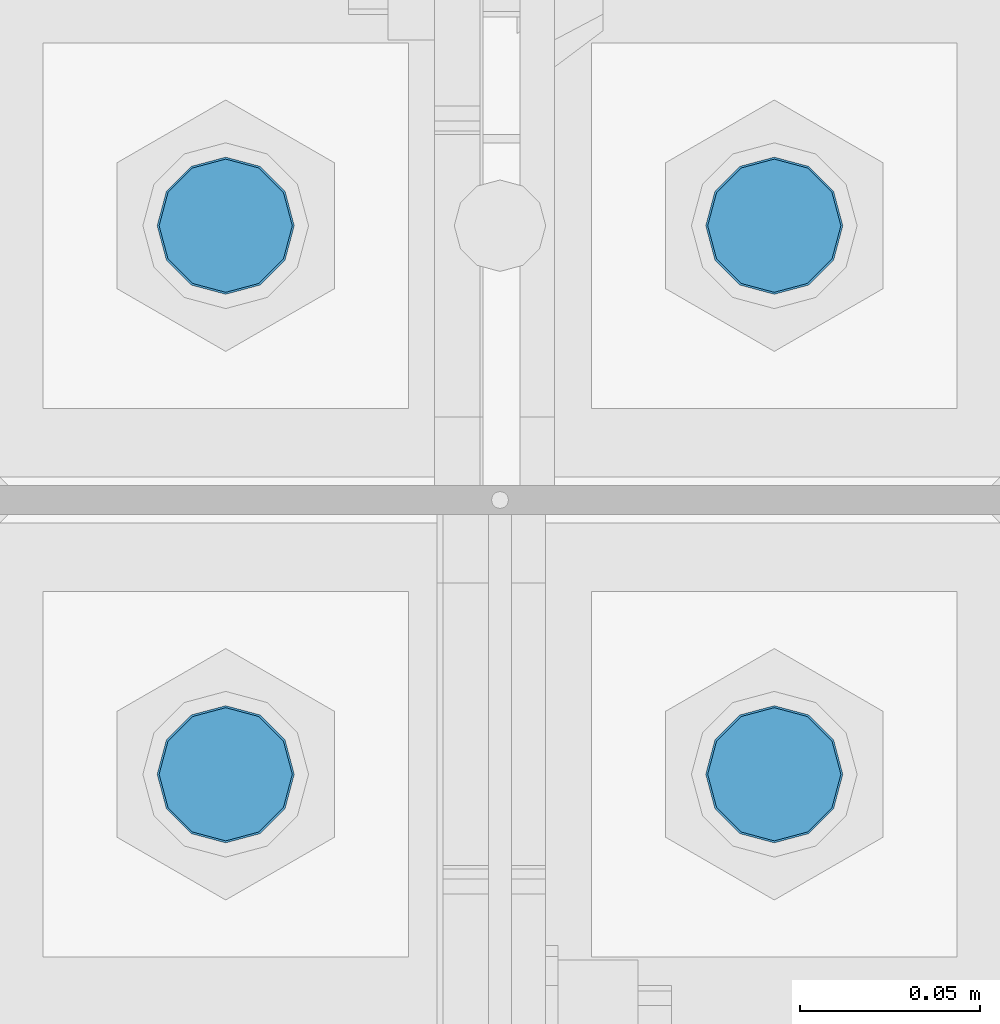
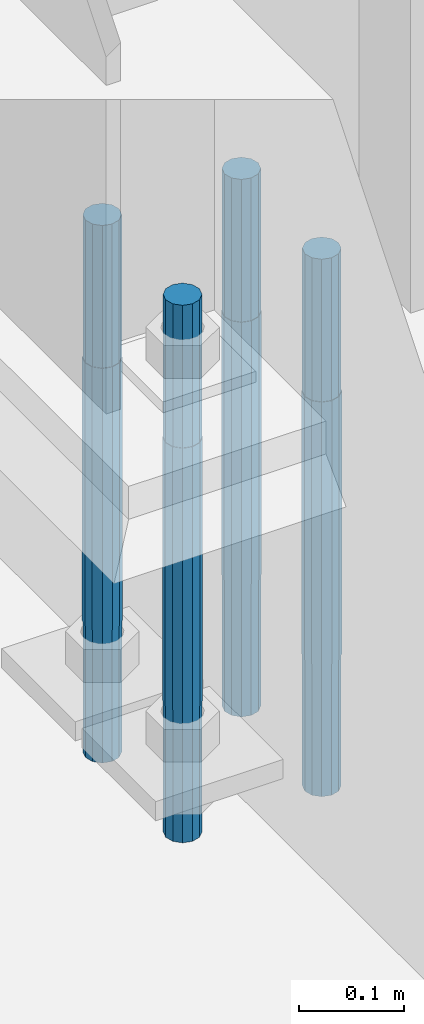
# One storey, part 1503 of 3843: 4 columns, 1 element without a shape of its own.
"""IFC2X3 building model written with IfcOpenShell, lengths in millimetres."""

from ifc_helpers import new_model, si_unit, frame, origin_with_axes, place, context, subcontext, project, spatial, faceted_brep, material, type_object, element, aggregate, save


model = new_model("IFC2X3")

# Units and contexts
model_context = context("Model", 3, precision=1e-05, world=origin_with_axes())
body_context = subcontext(model_context, "Body", "Model", "MODEL_VIEW")
ifc_project = project(units=[si_unit("LENGTHUNIT", "METRE", prefix="MILLI"), si_unit("AREAUNIT", "SQUARE_METRE"), si_unit("VOLUMEUNIT", "CUBIC_METRE"), si_unit("MASSUNIT", "GRAM", prefix="KILO"), si_unit("TIMEUNIT", "SECOND"), si_unit("PLANEANGLEUNIT", "RADIAN"), si_unit("SOLIDANGLEUNIT", "STERADIAN"), si_unit("THERMODYNAMICTEMPERATUREUNIT", "DEGREE_CELSIUS"), si_unit("LUMINOUSINTENSITYUNIT", "LUMEN")], contexts=[model_context])

# Site, building, storey
site_placement = place(None, origin_with_axes())
site = spatial("IfcSite", under=ifc_project, at=site_placement, CompositionType="ELEMENT")
building_placement = place(site_placement, origin_with_axes())
building = spatial("IfcBuilding", under=site, at=building_placement, Name="Undefined", CompositionType="ELEMENT")
storey_placement = place(building_placement, origin_with_axes())
storey = spatial("IfcBuildingStorey", under=building, at=storey_placement, Name="Undefined", CompositionType="ELEMENT", Elevation=0.0)

# Assembly, columns
assembly_placement = place(storey_placement, origin_with_axes())
assembly = element("IfcElementAssembly", 1, at=assembly_placement, inside=storey, Name="TEMPLATE", AssemblyPlace="NOTDEFINED", PredefinedType="RIGID_FRAME")
ifc_material = material(Name="Undefined/F1554-GR.55")
column_type = type_object("IfcColumnType", PredefinedType="NOTDEFINED")
column_1_placement = place(assembly_placement, frame((77089.0, 28638.5, 30022.8), z_axis=(1.0, 0.0, 0.0), x_axis=(0.0, 0.0, -1.0)))
column_1 = element("IfcColumn", 2, at=column_1_placement, type_object=column_type, material=ifc_material, Name="ANCHOR_ROD", context=body_context, shape_type="Brep", body=[
    faceted_brep([(-165.100000000002, -16.0214699700118, 9.25), (-165.100000000002, -9.25, 16.0214699700155), (-165.100000000002, 0.0, 18.5), (-165.100000000002, 9.25, 16.0214699700155), (-165.100000000002, 16.0214699700118, 9.25), (-165.100000000002, 18.5, 0.0), (-165.100000000002, 16.0214699700118, -9.25), (-165.100000000002, 9.25, -16.0214699700155), (-165.100000000002, 0.0, -18.5), (-165.100000000002, -9.25, -16.0214699700155), (-165.100000000002, -16.0214699700118, -9.25), (-165.100000000002, -18.5, 0.0), (0.0, 18.5, 0.0), (0.0, 16.0214699700118, -9.25), (0.0, 9.25, -16.0214699700155), (0.0, 0.0, -18.5), (0.0, -9.25, -16.0214699700155), (0.0, -16.0214699700118, -9.25), (0.0, -18.5, 0.0), (0.0, -16.0214699700118, 9.25), (0.0, -9.25, 16.0214699700155), (0.0, 0.0, 18.5), (0.0, 9.25, 16.0214699700155), (0.0, 16.0214699700118, 9.25), (0.0, -16.4977839420972, 9.52500000000146), (0.0, -9.52500000000146, 16.4977839420972), (0.0, 0.0, 19.0499989999989), (0.0, 9.52500000000146, 16.4977839420972), (0.0, 16.4977839420972, 9.52500000000146), (0.0, 19.0500000000029, 0.0), (0.0, 16.4977839420972, -9.52500000000146), (0.0, 9.52500000000146, -16.4977839420972), (0.0, 0.0, -19.0499989999989), (0.0, -9.52500000000146, -16.4977839420972), (0.0, -16.4977839420972, -9.52500000000146), (0.0, -19.0500000000029, 0.0), (304.799999999999, -19.0499999999993, 0.0), (304.799999999999, -16.4977839420935, 9.52499999999418), (304.799999999999, -9.52500000000146, 16.4977839420899), (304.799987999999, 0.0, 19.0499989999989), (304.799999999999, 9.52500000000146, 16.4977839420899), (304.799999999999, 16.4977839420935, 9.52499999999418), (304.799987792969, 19.0499999999993, 0.0), (304.799999999999, 16.4977839420935, -9.52499999999418), (304.799999999999, 9.52500000000146, -16.4977839420899), (304.799987999999, 0.0, -19.0499989999989), (304.799999999999, -9.52500000000146, -16.4977839420899), (304.799999999999, -16.4977839420935, -9.52499999999418), (304.799999999999, -9.25, 16.0214699700155), (304.799999999999, 0.0, 18.5), (304.799999999999, 9.25, 16.0214699700155), (304.799999999999, 16.0214699700118, 9.25), (304.799999999999, 18.5, 0.0), (304.799999999999, 16.0214699700118, -9.25), (304.799999999999, 9.25, -16.0214699700155), (304.799999999999, 0.0, -18.5), (304.799999999999, -9.25, -16.0214699700155), (304.799999999999, -16.0214699700118, -9.25), (304.799999999999, -18.5, 0.0), (304.799999999999, -16.0214699700118, 9.25), (457.200000000001, -9.25, -16.0214699700155), (457.200000000001, 0.0, -18.5), (457.200000000001, 9.25, -16.0214699700155), (457.200000000001, 16.0214699700118, -9.25), (457.200000000001, 18.5, 0.0), (457.200000000001, 16.0214699700118, 9.25), (457.200000000001, 9.25, 16.0214699700155), (457.200000000001, 0.0, 18.5), (457.200000000001, -9.25, 16.0214699700155), (457.200000000001, -16.0214699700118, 9.25), (457.200000000001, -18.5, 0.0), (457.200000000001, -16.0214699700118, -9.25)], [[[0, 1, 2, 3, 4, 5, 6, 7, 8, 9, 10, 11]], [[6, 5, 12, 13]], [[7, 6, 13, 14]], [[8, 7, 14, 15]], [[9, 8, 15, 16]], [[10, 9, 16, 17]], [[11, 10, 17, 18]], [[0, 11, 18, 19]], [[1, 0, 19, 20]], [[2, 1, 20, 21]], [[3, 2, 21, 22]], [[4, 3, 22, 23]], [[5, 4, 23, 12]], [[24, 25, 26, 27, 28, 29, 30, 31, 32, 33, 34, 35], [22, 21, 20, 19, 18, 17, 16, 15, 14, 13, 12, 23]], [[24, 35, 36, 37]], [[25, 24, 37, 38]], [[26, 25, 38, 39]], [[27, 26, 39, 40]], [[28, 27, 40, 41]], [[29, 28, 41, 42]], [[30, 29, 42, 43]], [[31, 30, 43, 44]], [[32, 31, 44, 45]], [[33, 32, 45, 46]], [[34, 33, 46, 47]], [[35, 34, 47, 36]], [[46, 45, 44, 43, 42, 41, 40, 39, 38, 37, 36, 47], [48, 49, 50, 51, 52, 53, 54, 55, 56, 57, 58, 59]], [[60, 61, 62, 63, 64, 65, 66, 67, 68, 69, 70, 71]], [[68, 67, 49, 48]], [[69, 68, 48, 59]], [[70, 69, 59, 58]], [[71, 70, 58, 57]], [[60, 71, 57, 56]], [[61, 60, 56, 55]], [[62, 61, 55, 54]], [[63, 62, 54, 53]], [[64, 63, 53, 52]], [[65, 64, 52, 51]], [[66, 65, 51, 50]], [[67, 66, 50, 49]]]),
])
column_2_placement = place(assembly_placement, frame((77089.0, 28790.9, 30022.8), z_axis=(-1.0, 0.0, 0.0), x_axis=(0.0, 0.0, -1.0)))
column_2 = element("IfcColumn", 3, at=column_2_placement, type_object=column_type, material=ifc_material, Name="ANCHOR_ROD", context=body_context, shape_type="Brep", body=[
    faceted_brep([(-165.100000000002, -16.0214699700118, 9.25), (-165.100000000002, -9.25, 16.0214699700155), (-165.100000000002, 0.0, 18.5), (-165.100000000002, 9.25, 16.0214699700155), (-165.100000000002, 16.0214699700118, 9.25), (-165.100000000002, 18.5, 0.0), (-165.100000000002, 16.0214699700118, -9.25), (-165.100000000002, 9.25, -16.0214699700155), (-165.100000000002, 0.0, -18.5), (-165.100000000002, -9.25, -16.0214699700155), (-165.100000000002, -16.0214699700118, -9.25), (-165.100000000002, -18.5, 0.0), (0.0, 18.5, 0.0), (0.0, 16.0214699700118, -9.25), (0.0, 9.25, -16.0214699700155), (0.0, 0.0, -18.5), (0.0, -9.25, -16.0214699700155), (0.0, -16.0214699700118, -9.25), (0.0, -18.5, 0.0), (0.0, -16.0214699700118, 9.25), (0.0, -9.25, 16.0214699700155), (0.0, 0.0, 18.5), (0.0, 9.25, 16.0214699700155), (0.0, 16.0214699700118, 9.25), (0.0, -16.4977839420972, 9.52500000000146), (0.0, -9.52500000000146, 16.4977839420972), (0.0, 0.0, 19.0499989999989), (0.0, 9.52500000000146, 16.4977839420972), (0.0, 16.4977839420972, 9.52500000000146), (0.0, 19.0500000000029, 0.0), (0.0, 16.4977839420972, -9.52500000000146), (0.0, 9.52500000000146, -16.4977839420972), (0.0, 0.0, -19.0499989999989), (0.0, -9.52500000000146, -16.4977839420972), (0.0, -16.4977839420972, -9.52500000000146), (0.0, -19.0500000000029, 0.0), (304.799999999999, -19.0499999999993, 0.0), (304.799999999999, -16.4977839420935, 9.52499999999418), (304.799999999999, -9.52500000000146, 16.4977839420899), (304.799987999999, 0.0, 19.0499989999989), (304.799999999999, 9.52500000000146, 16.4977839420899), (304.799999999999, 16.4977839420935, 9.52499999999418), (304.799987792969, 19.0499999999993, 0.0), (304.799999999999, 16.4977839420935, -9.52499999999418), (304.799999999999, 9.52500000000146, -16.4977839420899), (304.799987999999, 0.0, -19.0499989999989), (304.799999999999, -9.52500000000146, -16.4977839420899), (304.799999999999, -16.4977839420935, -9.52499999999418), (304.799999999999, -9.25, 16.0214699700155), (304.799999999999, 0.0, 18.5), (304.799999999999, 9.25, 16.0214699700155), (304.799999999999, 16.0214699700118, 9.25), (304.799999999999, 18.5, 0.0), (304.799999999999, 16.0214699700118, -9.25), (304.799999999999, 9.25, -16.0214699700155), (304.799999999999, 0.0, -18.5), (304.799999999999, -9.25, -16.0214699700155), (304.799999999999, -16.0214699700118, -9.25), (304.799999999999, -18.5, 0.0), (304.799999999999, -16.0214699700118, 9.25), (457.200000000001, -9.25, -16.0214699700155), (457.200000000001, 0.0, -18.5), (457.200000000001, 9.25, -16.0214699700155), (457.200000000001, 16.0214699700118, -9.25), (457.200000000001, 18.5, 0.0), (457.200000000001, 16.0214699700118, 9.25), (457.200000000001, 9.25, 16.0214699700155), (457.200000000001, 0.0, 18.5), (457.200000000001, -9.25, 16.0214699700155), (457.200000000001, -16.0214699700118, 9.25), (457.200000000001, -18.5, 0.0), (457.200000000001, -16.0214699700118, -9.25)], [[[0, 1, 2, 3, 4, 5, 6, 7, 8, 9, 10, 11]], [[6, 5, 12, 13]], [[7, 6, 13, 14]], [[8, 7, 14, 15]], [[9, 8, 15, 16]], [[10, 9, 16, 17]], [[11, 10, 17, 18]], [[0, 11, 18, 19]], [[1, 0, 19, 20]], [[2, 1, 20, 21]], [[3, 2, 21, 22]], [[4, 3, 22, 23]], [[5, 4, 23, 12]], [[24, 25, 26, 27, 28, 29, 30, 31, 32, 33, 34, 35], [22, 21, 20, 19, 18, 17, 16, 15, 14, 13, 12, 23]], [[24, 35, 36, 37]], [[25, 24, 37, 38]], [[26, 25, 38, 39]], [[27, 26, 39, 40]], [[28, 27, 40, 41]], [[29, 28, 41, 42]], [[30, 29, 42, 43]], [[31, 30, 43, 44]], [[32, 31, 44, 45]], [[33, 32, 45, 46]], [[34, 33, 46, 47]], [[35, 34, 47, 36]], [[46, 45, 44, 43, 42, 41, 40, 39, 38, 37, 36, 47], [48, 49, 50, 51, 52, 53, 54, 55, 56, 57, 58, 59]], [[60, 61, 62, 63, 64, 65, 66, 67, 68, 69, 70, 71]], [[68, 67, 49, 48]], [[69, 68, 48, 59]], [[70, 69, 59, 58]], [[71, 70, 58, 57]], [[60, 71, 57, 56]], [[61, 60, 56, 55]], [[62, 61, 55, 54]], [[63, 62, 54, 53]], [[64, 63, 53, 52]], [[65, 64, 52, 51]], [[66, 65, 51, 50]], [[67, 66, 50, 49]]]),
])
column_3_placement = place(assembly_placement, frame((76936.6, 28638.5, 30022.8), z_axis=(1.0, 0.0, 0.0), x_axis=(0.0, 0.0, -1.0)))
column_3 = element("IfcColumn", 4, at=column_3_placement, type_object=column_type, material=ifc_material, Name="ANCHOR_ROD", context=body_context, shape_type="Brep", body=[
    faceted_brep([(-165.100000000002, -16.0214699700118, 9.25), (-165.100000000002, -9.25, 16.0214699700155), (-165.100000000002, 0.0, 18.5), (-165.100000000002, 9.25, 16.0214699700155), (-165.100000000002, 16.0214699700118, 9.25), (-165.100000000002, 18.5, 0.0), (-165.100000000002, 16.0214699700118, -9.25), (-165.100000000002, 9.25, -16.0214699700155), (-165.100000000002, 0.0, -18.5), (-165.100000000002, -9.25, -16.0214699700155), (-165.100000000002, -16.0214699700118, -9.25), (-165.100000000002, -18.5, 0.0), (0.0, 18.5, 0.0), (0.0, 16.0214699700118, -9.25), (0.0, 9.25, -16.0214699700155), (0.0, 0.0, -18.5), (0.0, -9.25, -16.0214699700155), (0.0, -16.0214699700118, -9.25), (0.0, -18.5, 0.0), (0.0, -16.0214699700118, 9.25), (0.0, -9.25, 16.0214699700155), (0.0, 0.0, 18.5), (0.0, 9.25, 16.0214699700155), (0.0, 16.0214699700118, 9.25), (0.0, -16.4977839420972, 9.52500000000146), (0.0, -9.52500000000146, 16.4977839420972), (0.0, 0.0, 19.0499989999989), (0.0, 9.52500000000146, 16.4977839420972), (0.0, 16.4977839420972, 9.52500000000146), (0.0, 19.0500000000029, 0.0), (0.0, 16.4977839420972, -9.52500000000146), (0.0, 9.52500000000146, -16.4977839420972), (0.0, 0.0, -19.0499989999989), (0.0, -9.52500000000146, -16.4977839420972), (0.0, -16.4977839420972, -9.52500000000146), (0.0, -19.0500000000029, 0.0), (304.799999999999, -19.0499999999993, 0.0), (304.799999999999, -16.4977839420935, 9.52499999999418), (304.799999999999, -9.52500000000146, 16.4977839420899), (304.799987999999, 0.0, 19.0499989999989), (304.799999999999, 9.52500000000146, 16.4977839420899), (304.799999999999, 16.4977839420935, 9.52499999999418), (304.799987792969, 19.0499999999993, 0.0), (304.799999999999, 16.4977839420935, -9.52499999999418), (304.799999999999, 9.52500000000146, -16.4977839420899), (304.799987999999, 0.0, -19.0499989999989), (304.799999999999, -9.52500000000146, -16.4977839420899), (304.799999999999, -16.4977839420935, -9.52499999999418), (304.799999999999, -9.25, 16.0214699700155), (304.799999999999, 0.0, 18.5), (304.799999999999, 9.25, 16.0214699700155), (304.799999999999, 16.0214699700118, 9.25), (304.799999999999, 18.5, 0.0), (304.799999999999, 16.0214699700118, -9.25), (304.799999999999, 9.25, -16.0214699700155), (304.799999999999, 0.0, -18.5), (304.799999999999, -9.25, -16.0214699700155), (304.799999999999, -16.0214699700118, -9.25), (304.799999999999, -18.5, 0.0), (304.799999999999, -16.0214699700118, 9.25), (457.200000000001, -9.25, -16.0214699700155), (457.200000000001, 0.0, -18.5), (457.200000000001, 9.25, -16.0214699700155), (457.200000000001, 16.0214699700118, -9.25), (457.200000000001, 18.5, 0.0), (457.200000000001, 16.0214699700118, 9.25), (457.200000000001, 9.25, 16.0214699700155), (457.200000000001, 0.0, 18.5), (457.200000000001, -9.25, 16.0214699700155), (457.200000000001, -16.0214699700118, 9.25), (457.200000000001, -18.5, 0.0), (457.200000000001, -16.0214699700118, -9.25)], [[[0, 1, 2, 3, 4, 5, 6, 7, 8, 9, 10, 11]], [[6, 5, 12, 13]], [[7, 6, 13, 14]], [[8, 7, 14, 15]], [[9, 8, 15, 16]], [[10, 9, 16, 17]], [[11, 10, 17, 18]], [[0, 11, 18, 19]], [[1, 0, 19, 20]], [[2, 1, 20, 21]], [[3, 2, 21, 22]], [[4, 3, 22, 23]], [[5, 4, 23, 12]], [[24, 25, 26, 27, 28, 29, 30, 31, 32, 33, 34, 35], [22, 21, 20, 19, 18, 17, 16, 15, 14, 13, 12, 23]], [[24, 35, 36, 37]], [[25, 24, 37, 38]], [[26, 25, 38, 39]], [[27, 26, 39, 40]], [[28, 27, 40, 41]], [[29, 28, 41, 42]], [[30, 29, 42, 43]], [[31, 30, 43, 44]], [[32, 31, 44, 45]], [[33, 32, 45, 46]], [[34, 33, 46, 47]], [[35, 34, 47, 36]], [[46, 45, 44, 43, 42, 41, 40, 39, 38, 37, 36, 47], [48, 49, 50, 51, 52, 53, 54, 55, 56, 57, 58, 59]], [[60, 61, 62, 63, 64, 65, 66, 67, 68, 69, 70, 71]], [[68, 67, 49, 48]], [[69, 68, 48, 59]], [[70, 69, 59, 58]], [[71, 70, 58, 57]], [[60, 71, 57, 56]], [[61, 60, 56, 55]], [[62, 61, 55, 54]], [[63, 62, 54, 53]], [[64, 63, 53, 52]], [[65, 64, 52, 51]], [[66, 65, 51, 50]], [[67, 66, 50, 49]]]),
])
column_4_placement = place(assembly_placement, frame((76936.6, 28790.9, 30022.8), z_axis=(-1.0, 0.0, 0.0), x_axis=(0.0, 0.0, -1.0)))
column_4 = element("IfcColumn", 5, at=column_4_placement, type_object=column_type, material=ifc_material, Name="ANCHOR_ROD", context=body_context, shape_type="Brep", body=[
    faceted_brep([(-165.100000000002, -16.0214699700118, 9.25), (-165.100000000002, -9.25, 16.0214699700155), (-165.100000000002, 0.0, 18.5), (-165.100000000002, 9.25, 16.0214699700155), (-165.100000000002, 16.0214699700118, 9.25), (-165.100000000002, 18.5, 0.0), (-165.100000000002, 16.0214699700118, -9.25), (-165.100000000002, 9.25, -16.0214699700155), (-165.100000000002, 0.0, -18.5), (-165.100000000002, -9.25, -16.0214699700155), (-165.100000000002, -16.0214699700118, -9.25), (-165.100000000002, -18.5, 0.0), (0.0, 18.5, 0.0), (0.0, 16.0214699700118, -9.25), (0.0, 9.25, -16.0214699700155), (0.0, 0.0, -18.5), (0.0, -9.25, -16.0214699700155), (0.0, -16.0214699700118, -9.25), (0.0, -18.5, 0.0), (0.0, -16.0214699700118, 9.25), (0.0, -9.25, 16.0214699700155), (0.0, 0.0, 18.5), (0.0, 9.25, 16.0214699700155), (0.0, 16.0214699700118, 9.25), (0.0, -16.4977839420972, 9.52500000000146), (0.0, -9.52500000000146, 16.4977839420972), (0.0, 0.0, 19.0499989999989), (0.0, 9.52500000000146, 16.4977839420972), (0.0, 16.4977839420972, 9.52500000000146), (0.0, 19.0500000000029, 0.0), (0.0, 16.4977839420972, -9.52500000000146), (0.0, 9.52500000000146, -16.4977839420972), (0.0, 0.0, -19.0499989999989), (0.0, -9.52500000000146, -16.4977839420972), (0.0, -16.4977839420972, -9.52500000000146), (0.0, -19.0500000000029, 0.0), (304.799999999999, -19.0499999999993, 0.0), (304.799999999999, -16.4977839420935, 9.52499999999418), (304.799999999999, -9.52500000000146, 16.4977839420899), (304.799987999999, 0.0, 19.0499989999989), (304.799999999999, 9.52500000000146, 16.4977839420899), (304.799999999999, 16.4977839420935, 9.52499999999418), (304.799987792969, 19.0499999999993, 0.0), (304.799999999999, 16.4977839420935, -9.52499999999418), (304.799999999999, 9.52500000000146, -16.4977839420899), (304.799987999999, 0.0, -19.0499989999989), (304.799999999999, -9.52500000000146, -16.4977839420899), (304.799999999999, -16.4977839420935, -9.52499999999418), (304.799999999999, -9.25, 16.0214699700155), (304.799999999999, 0.0, 18.5), (304.799999999999, 9.25, 16.0214699700155), (304.799999999999, 16.0214699700118, 9.25), (304.799999999999, 18.5, 0.0), (304.799999999999, 16.0214699700118, -9.25), (304.799999999999, 9.25, -16.0214699700155), (304.799999999999, 0.0, -18.5), (304.799999999999, -9.25, -16.0214699700155), (304.799999999999, -16.0214699700118, -9.25), (304.799999999999, -18.5, 0.0), (304.799999999999, -16.0214699700118, 9.25), (457.200000000001, -9.25, -16.0214699700155), (457.200000000001, 0.0, -18.5), (457.200000000001, 9.25, -16.0214699700155), (457.200000000001, 16.0214699700118, -9.25), (457.200000000001, 18.5, 0.0), (457.200000000001, 16.0214699700118, 9.25), (457.200000000001, 9.25, 16.0214699700155), (457.200000000001, 0.0, 18.5), (457.200000000001, -9.25, 16.0214699700155), (457.200000000001, -16.0214699700118, 9.25), (457.200000000001, -18.5, 0.0), (457.200000000001, -16.0214699700118, -9.25)], [[[0, 1, 2, 3, 4, 5, 6, 7, 8, 9, 10, 11]], [[6, 5, 12, 13]], [[7, 6, 13, 14]], [[8, 7, 14, 15]], [[9, 8, 15, 16]], [[10, 9, 16, 17]], [[11, 10, 17, 18]], [[0, 11, 18, 19]], [[1, 0, 19, 20]], [[2, 1, 20, 21]], [[3, 2, 21, 22]], [[4, 3, 22, 23]], [[5, 4, 23, 12]], [[24, 25, 26, 27, 28, 29, 30, 31, 32, 33, 34, 35], [22, 21, 20, 19, 18, 17, 16, 15, 14, 13, 12, 23]], [[24, 35, 36, 37]], [[25, 24, 37, 38]], [[26, 25, 38, 39]], [[27, 26, 39, 40]], [[28, 27, 40, 41]], [[29, 28, 41, 42]], [[30, 29, 42, 43]], [[31, 30, 43, 44]], [[32, 31, 44, 45]], [[33, 32, 45, 46]], [[34, 33, 46, 47]], [[35, 34, 47, 36]], [[46, 45, 44, 43, 42, 41, 40, 39, 38, 37, 36, 47], [48, 49, 50, 51, 52, 53, 54, 55, 56, 57, 58, 59]], [[60, 61, 62, 63, 64, 65, 66, 67, 68, 69, 70, 71]], [[68, 67, 49, 48]], [[69, 68, 48, 59]], [[70, 69, 59, 58]], [[71, 70, 58, 57]], [[60, 71, 57, 56]], [[61, 60, 56, 55]], [[62, 61, 55, 54]], [[63, 62, 54, 53]], [[64, 63, 53, 52]], [[65, 64, 52, 51]], [[66, 65, 51, 50]], [[67, 66, 50, 49]]]),
])
aggregate(assembly, [column_1, column_2, column_3, column_4])

save(model, "model.ifc")
